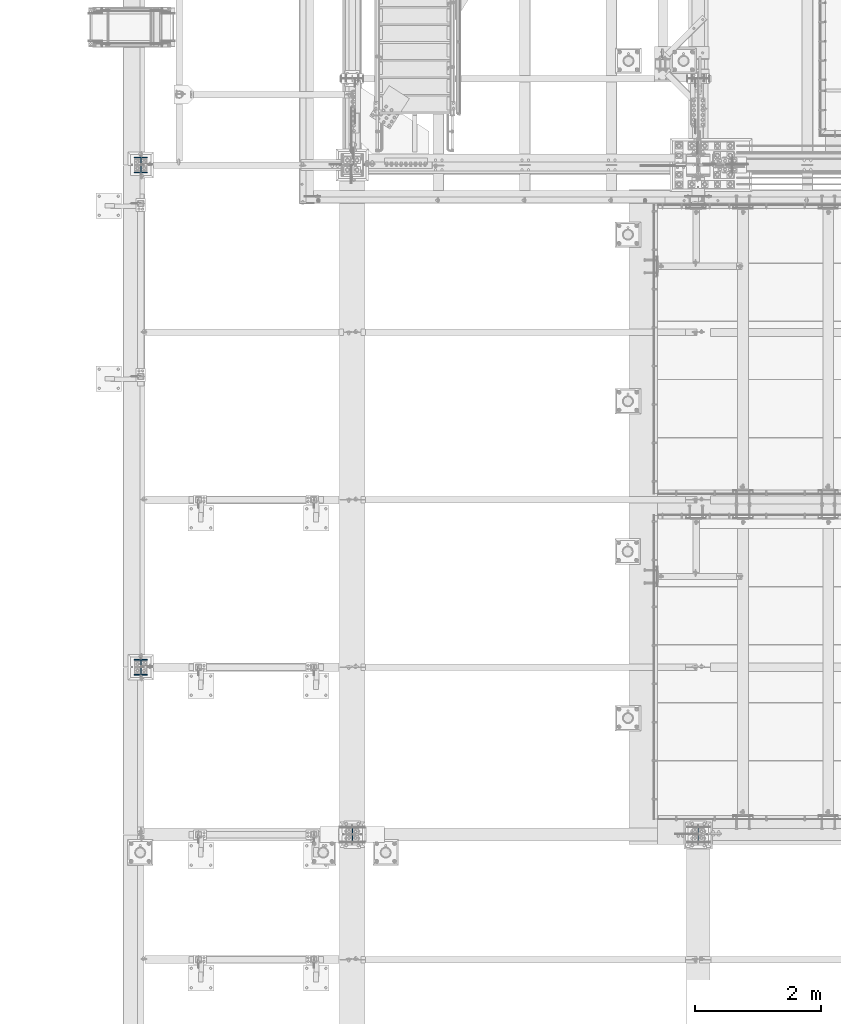
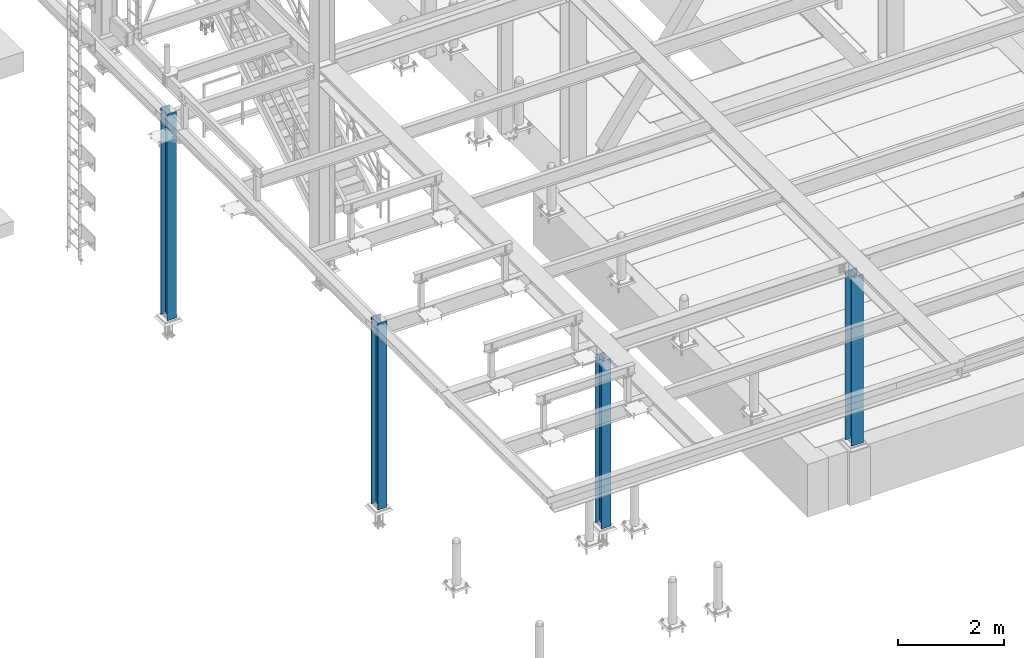
# One storey, part 1276 of 3843: 4 columns, 4 elements without a shape of their own.
"""IFC2X3 building model written with IfcOpenShell, lengths in millimetres."""

import ifcopenshell
import ifcopenshell.guid

model = None  # the IFC model being written
_history = None  # IfcOwnerHistory: only IFC2X3 demands one
_inside = {}  # id of a spatial element -> (the spatial element, [elements in it])
_under = {}  # id of a project, library or spatial element -> (it, [spatial elements below it])
_declared = {}  # id of a project -> (the project, [libraries it declares])
_typed = {}  # id of a type object -> (the type object, [elements of that type])
_made_of = {}  # id of a material, layer set ... -> (it, [elements and type objects made of it])


def new_model(schema):
    """Start an empty IFC model of exactly this schema.

    Asked for "IFC4X3", IfcOpenShell would pick the latest addendum, in which some entities
    have other attributes; the version numbers below select the first issue.
    IFC2X3 requires an IfcOwnerHistory on every rooted entity: one is made here for all.
    """
    global model, _history
    if schema == "IFC4X3":
        model = ifcopenshell.file(schema_version=(4, 3, 0, 0))
    else:
        model = ifcopenshell.file(schema=schema)
    _inside.clear()
    _under.clear()
    _declared.clear()
    _typed.clear()
    _made_of.clear()
    _history = None
    if model.schema == "IFC2X3":
        org = make("IfcOrganization", Name="unknown")
        user = make(
            "IfcPersonAndOrganization",
            ThePerson=make("IfcPerson", FamilyName="unknown"),
            TheOrganization=org,
        )
        app = make(
            "IfcApplication",
            ApplicationDeveloper=org,
            Version="unknown",
            ApplicationFullName="unknown",
            ApplicationIdentifier="unknown",
        )
        _history = make(
            "IfcOwnerHistory",
            OwningUser=user,
            OwningApplication=app,
            ChangeAction="ADDED",
            CreationDate=0,
        )
    return model


def make(cls, **values):
    """One entity of the class cls with the attributes given. An attribute that is None is left unset."""
    return model.create_entity(
        cls, **{name: value for name, value in values.items() if value is not None}
    )


def rooted(cls, **values):
    """An entity with a GlobalId (a new one), such as an element, a storey or a relation."""
    return make(cls, GlobalId=ifcopenshell.guid.new(), OwnerHistory=_history, **values)


def si_unit(unit_type, name, prefix=None):
    """IfcSIUnit, for example si_unit("LENGTHUNIT", "METRE", prefix="MILLI")."""
    return make("IfcSIUnit", UnitType=unit_type, Prefix=prefix, Name=name)


def assignment(units):
    """IfcUnitAssignment: the units of a project."""
    return None if units is None else make("IfcUnitAssignment", Units=units)


def point(xyz):
    """IfcCartesianPoint."""
    return None if xyz is None else make("IfcCartesianPoint", Coordinates=xyz)


def direction(xyz):
    """IfcDirection."""
    return None if xyz is None else make("IfcDirection", DirectionRatios=xyz)


def frame(location, z_axis=None, x_axis=None):
    """IfcAxis2Placement3D, a coordinate frame: its origin and axes. An axis left out is left unset."""
    return make(
        "IfcAxis2Placement3D",
        Location=point(location),
        Axis=direction(z_axis),
        RefDirection=direction(x_axis),
    )


def origin_with_axes():
    """The frame at (0, 0, 0) with the z axis (0, 0, 1) and the x axis (1, 0, 0) written out."""
    return frame((0.0, 0.0, 0.0), z_axis=(0.0, 0.0, 1.0), x_axis=(1.0, 0.0, 0.0))


def place(relative_to, where):
    """IfcLocalPlacement: puts the frame where relative to a parent placement (None: the world)."""
    return make(
        "IfcLocalPlacement", PlacementRelTo=relative_to, RelativePlacement=where
    )


def context(
    kind, dimensions, precision=None, world=None, true_north=None, identifier=None
):
    """IfcGeometricRepresentationContext, for example the 3D "Model" context."""
    return make(
        "IfcGeometricRepresentationContext",
        ContextIdentifier=identifier,
        ContextType=kind,
        CoordinateSpaceDimension=dimensions,
        Precision=precision,
        WorldCoordinateSystem=world,
        TrueNorth=true_north,
    )


def subcontext(parent, identifier, kind, view, scale=None):
    """IfcGeometricRepresentationSubContext, for example "Body" below "Model"."""
    return make(
        "IfcGeometricRepresentationSubContext",
        ContextIdentifier=identifier,
        ContextType=kind,
        ParentContext=parent,
        TargetScale=scale,
        TargetView=view,
    )


def project(units=None, contexts=None):
    """IfcProject with its units and contexts."""
    return rooted(
        "IfcProject",
        Name="project",
        RepresentationContexts=contexts,
        UnitsInContext=assignment(units),
    )


def spatial(cls, under=None, at=None, **own):
    """A site, building, storey or space (cls), placed at a placement, below another one or the project."""
    s = rooted(cls, ObjectPlacement=at, **own)
    if under is not None:
        _under.setdefault(under.id(), (under, []))[1].append(s)
    return s


def faces_of(points, faces, orient=None, outer=None):
    """IfcFace entities. A face is a list of loops; a loop is a list of indices into points, from 0.

    orient and outer hold one flag for each loop. By default every Orientation is true, the
    first loop of a face is its IfcFaceOuterBound and the others are IfcFaceBound.
    """
    made = []
    for i, loops in enumerate(faces):
        bounds = []
        for j, loop in enumerate(loops):
            is_outer = j == 0 if outer is None else outer[i][j]
            bounds.append(
                make(
                    "IfcFaceOuterBound" if is_outer else "IfcFaceBound",
                    Bound=make("IfcPolyLoop", Polygon=[points[k] for k in loop]),
                    Orientation=True if orient is None else orient[i][j],
                )
            )
        made.append(make("IfcFace", Bounds=bounds))
    return made


def faceted_brep(points, faces, orient=None, outer=None, voids=None):
    """IfcFacetedBrep: a solid bounded by flat faces; with voids (closed shells), ...WithVoids."""
    shared = [point(p) for p in points]
    hull = make("IfcClosedShell", CfsFaces=faces_of(shared, faces, orient, outer))
    if voids is None:
        return make("IfcFacetedBrep", Outer=hull)
    return make(
        "IfcFacetedBrepWithVoids",
        Outer=hull,
        Voids=[
            make(cls, CfsFaces=faces_of(shared, fs, o, b)) for cls, fs, o, b in voids
        ],
    )


def shape(context_of_items, identifier, shape_type, items):
    """IfcShapeRepresentation: the items that make up one representation, for example the "Body"."""
    return make(
        "IfcShapeRepresentation",
        ContextOfItems=context_of_items,
        RepresentationIdentifier=identifier,
        RepresentationType=shape_type,
        Items=items,
    )


def material(Name=None, Category=None):
    """IfcMaterial."""
    return make("IfcMaterial", Name=Name, Category=Category)


def made_of(thing, what):
    """Note that an element or type object is made of a material, layer set ...; save() writes the relation."""
    if what is not None:
        _made_of.setdefault(what.id(), (what, []))[1].append(thing)
    return thing


def type_object(cls, material=None, **own):
    """A type object (cls), such as IfcWallType, which elements share."""
    return made_of(rooted(cls, **own), material)


def element(
    cls,
    number,
    at=None,
    inside=None,
    cuts=None,
    type_object=None,
    material=None,
    context=None,
    identifier="Body",
    shape_type=None,
    held_by="IfcProductDefinitionShape",
    body=None,
    shapes=None,
    **own,
):
    """One element of the class cls, such as IfcWall. Its Tag is "e" and its number.

    at: its placement. inside: the storey or other place that contains it. cuts: it is an
    opening in that element (IfcRelVoidsElement). A single representation is given by context,
    identifier, shape_type and body (its items); several are given by shapes. held_by: the class
    of the entity that holds the representations. save() writes the other relations.
    """
    e = rooted(cls, Tag="e%d" % number, ObjectPlacement=at, **own)
    if body is not None:
        shapes = [shape(context, identifier, shape_type, body)]
    if shapes is not None:
        e.Representation = make(held_by, Representations=shapes)
    if inside is not None:
        _inside.setdefault(inside.id(), (inside, []))[1].append(e)
    if cuts is not None:
        rooted(
            "IfcRelVoidsElement", RelatingBuildingElement=cuts, RelatedOpeningElement=e
        )
    if type_object is not None:
        _typed.setdefault(type_object.id(), (type_object, []))[1].append(e)
    return made_of(e, material)


def aggregate(whole, parts):
    """IfcRelAggregates: a whole, such as a stair, and the parts it consists of."""
    return rooted("IfcRelAggregates", RelatingObject=whole, RelatedObjects=parts)


def save(model, path):
    """Write the relations noted so far, then the file.

    IfcRelAggregates (storeys below a building ...), IfcRelContainedInSpatialStructure (elements
    in a storey), IfcRelDefinesByType, IfcRelAssociatesMaterial and IfcRelDeclares: one each for
    every whole, place, type object, material and project.
    """
    for whole, parts in _under.values():
        aggregate(whole, parts)
    for where, things in _inside.values():
        rooted(
            "IfcRelContainedInSpatialStructure",
            RelatedElements=things,
            RelatingStructure=where,
        )
    for kind, things in _typed.values():
        rooted("IfcRelDefinesByType", RelatedObjects=things, RelatingType=kind)
    for what, things in _made_of.values():
        rooted("IfcRelAssociatesMaterial", RelatedObjects=things, RelatingMaterial=what)
    for by, libraries in _declared.values():
        rooted("IfcRelDeclares", RelatingContext=by, RelatedDefinitions=libraries)
    model.write(path)


model = new_model("IFC2X3")

# Units and contexts
model_context = context("Model", 3, precision=1e-05, world=origin_with_axes())
body_context = subcontext(model_context, "Body", "Model", "MODEL_VIEW")
ifc_project = project(units=[si_unit("LENGTHUNIT", "METRE", prefix="MILLI"), si_unit("AREAUNIT", "SQUARE_METRE"), si_unit("VOLUMEUNIT", "CUBIC_METRE"), si_unit("MASSUNIT", "GRAM", prefix="KILO"), si_unit("TIMEUNIT", "SECOND"), si_unit("PLANEANGLEUNIT", "RADIAN"), si_unit("SOLIDANGLEUNIT", "STERADIAN"), si_unit("THERMODYNAMICTEMPERATUREUNIT", "DEGREE_CELSIUS"), si_unit("LUMINOUSINTENSITYUNIT", "LUMEN")], contexts=[model_context])

# Site, building, storey
site_placement = place(None, origin_with_axes())
site = spatial("IfcSite", under=ifc_project, at=site_placement, CompositionType="ELEMENT")
building_placement = place(site_placement, origin_with_axes())
building = spatial("IfcBuilding", under=site, at=building_placement, Name="Undefined", CompositionType="ELEMENT")
storey_placement = place(building_placement, origin_with_axes())
storey = spatial("IfcBuildingStorey", under=building, at=storey_placement, Name="Undefined", CompositionType="ELEMENT", Elevation=0.0)

# Assembly, column
assembly_1_placement = place(storey_placement, origin_with_axes())
assembly_1 = element("IfcElementAssembly", 1, at=assembly_1_placement, inside=storey, Name="COLUMN", AssemblyPlace="NOTDEFINED", PredefinedType="RIGID_FRAME")
ifc_material = material(Name="STEEL/A992")
column_type_1 = type_object("IfcColumnType", Name="W10X60", PredefinedType="NOTDEFINED")
column_1_placement = place(assembly_1_placement, frame((42062.4, 14998.7, 30480.0), z_axis=(0.0, 1.0, 0.0), x_axis=(0.0, 0.0, 1.0)))
column_1 = element("IfcColumn", 2, at=column_1_placement, type_object=column_type_1, material=ifc_material, Name="COLUMN", ObjectType="W10X60", context=body_context, shape_type="Brep", body=[
    faceted_brep([(63.5, 128.587499999994, -130.174999999999), (63.5, 128.587499999994, -112.7125), (3952.87500000001, 128.587500000001, -112.7125), (3952.87500000001, 128.587500000001, -130.174999999999), (63.5, 5.55624999999418, -112.7125), (3952.87500000001, 5.55625000000146, -112.7125), (63.5, 5.55624999999418, 112.7125), (3952.87500000001, 5.55625000000146, 112.7125), (63.5, 128.587499999994, 112.7125), (3952.87500000001, 128.587500000001, 112.7125), (63.5, 128.587499999994, 130.174999999999), (3952.87500000001, 128.587500000001, 130.174999999999), (63.5, -128.587499999994, 130.174999999999), (3952.87500000001, -128.587500000001, 130.174999999999), (63.5, -128.587499999994, 112.7125), (3952.87500000001, -128.587500000001, 112.7125), (63.5, -5.55624999999418, 112.7125), (3952.87500000001, -5.55625000000146, 112.7125), (63.5, -5.55624999999418, -112.7125), (3952.87500000001, -5.55625000000146, -112.7125), (63.5, -128.587499999994, -112.7125), (3952.87500000001, -128.587500000001, -112.7125), (63.5, -128.587499999994, -130.174999999999), (3952.87500000001, -128.587500000001, -130.174999999999)], [[[0, 1, 2, 3]], [[1, 4, 5, 2]], [[4, 6, 7, 5]], [[6, 8, 9, 7]], [[8, 10, 11, 9]], [[10, 12, 13, 11]], [[12, 14, 15, 13]], [[14, 16, 17, 15]], [[16, 18, 19, 17]], [[18, 20, 21, 19]], [[20, 22, 23, 21]], [[22, 0, 3, 23]], [[5, 7, 9, 11, 13, 15, 17, 19, 21, 23, 3, 2]], [[22, 20, 18, 16, 14, 12, 10, 8, 6, 4, 1, 0]]]),
])
aggregate(assembly_1, [column_1])

assembly_2_placement = place(storey_placement, origin_with_axes())
assembly_2 = element("IfcElementAssembly", 3, at=assembly_2_placement, inside=storey, Name="COLUMN", AssemblyPlace="NOTDEFINED", PredefinedType="RIGID_FRAME")
column_type_2 = type_object("IfcColumnType", Name="W10X39", PredefinedType="NOTDEFINED")
column_2_placement = place(assembly_2_placement, frame((36576.0, 14998.7, 30480.0), z_axis=(0.0, 1.0, 0.0), x_axis=(0.0, 0.0, 1.0)))
column_2 = element("IfcColumn", 4, at=column_2_placement, type_object=column_type_2, material=ifc_material, Name="COLUMN", ObjectType="W10X39", context=body_context, shape_type="Brep", body=[
    faceted_brep([(63.4999999999964, 101.600000000006, -125.4125), (63.4999999999964, 101.600000000006, -112.7125), (3930.65, 101.599999999999, -112.7125), (3930.65, 101.599999999999, -125.4125), (63.4999999999964, 3.96875, -112.7125), (3930.65, 3.96875, -112.7125), (63.4999999999964, 3.96875, 112.7125), (3930.65, 3.96875, 112.7125), (63.4999999999964, 101.600000000006, 112.7125), (3930.65, 101.599999999999, 112.7125), (63.4999999999964, 101.600000000006, 125.4125), (3930.65, 101.599999999999, 125.4125), (63.4999999999964, -101.600000000006, 125.4125), (3930.65, -101.599999999999, 125.4125), (63.4999999999964, -101.600000000006, 112.7125), (3930.65, -101.599999999999, 112.7125), (63.4999999999964, -3.96875, 112.7125), (3930.65, -3.96875, 112.7125), (63.4999999999964, -3.96875, -112.7125), (3930.65, -3.96875, -112.7125), (63.4999999999964, -101.600000000006, -112.7125), (3930.65, -101.599999999999, -112.7125), (63.4999999999964, -101.600000000006, -125.4125), (3930.65, -101.599999999999, -125.4125)], [[[0, 1, 2, 3]], [[1, 4, 5, 2]], [[4, 6, 7, 5]], [[6, 8, 9, 7]], [[8, 10, 11, 9]], [[10, 12, 13, 11]], [[12, 14, 15, 13]], [[14, 16, 17, 15]], [[16, 18, 19, 17]], [[18, 20, 21, 19]], [[20, 22, 23, 21]], [[22, 0, 3, 23]], [[5, 7, 9, 11, 13, 15, 17, 19, 21, 23, 3, 2]], [[22, 20, 18, 16, 14, 12, 10, 8, 6, 4, 1, 0]]]),
])
aggregate(assembly_2, [column_2])

assembly_3_placement = place(storey_placement, origin_with_axes())
assembly_3 = element("IfcElementAssembly", 5, at=assembly_3_placement, inside=storey, Name="COLUMN", AssemblyPlace="NOTDEFINED", PredefinedType="RIGID_FRAME")
column_3_placement = place(assembly_3_placement, frame((33223.2, 17653.0, 30480.0), z_axis=(0.0, 1.0, 0.0), x_axis=(0.0, 0.0, 1.0)))
column_3 = element("IfcColumn", 6, at=column_3_placement, type_object=column_type_2, material=ifc_material, Name="COLUMN", ObjectType="W10X39", context=body_context, shape_type="Brep", body=[
    faceted_brep([(63.4999999999964, 101.600000000006, -125.4125), (63.4999999999964, 101.600000000006, -112.7125), (4368.8, 101.599999999999, -112.712500000001), (4368.8, 101.599999999999, -125.412499999999), (63.4999999999964, 3.96875, -112.7125), (4368.8, 3.96875, -112.712500000001), (63.4999999999964, 3.96875, 112.7125), (4368.8, 3.96875, 112.712500000001), (63.4999999999964, 101.600000000006, 112.7125), (4368.8, 101.599999999999, 112.712500000001), (63.4999999999964, 101.600000000006, 125.4125), (4368.8, 101.599999999999, 125.412499999999), (63.4999999999964, -101.600000000006, 125.4125), (4368.8, -101.599999999999, 125.412499999999), (63.4999999999964, -101.600000000006, 112.7125), (4368.8, -101.599999999999, 112.712500000001), (63.4999999999964, -3.96875, 112.7125), (4368.8, -3.96875, 112.712500000001), (63.4999999999964, -3.96875, -112.7125), (4368.8, -3.96875, -112.712500000001), (63.4999999999964, -101.600000000006, -112.7125), (4368.8, -101.599999999999, -112.712500000001), (63.4999999999964, -101.600000000006, -125.4125), (4368.8, -101.599999999999, -125.412499999999)], [[[0, 1, 2, 3]], [[1, 4, 5, 2]], [[4, 6, 7, 5]], [[6, 8, 9, 7]], [[8, 10, 11, 9]], [[10, 12, 13, 11]], [[12, 14, 15, 13]], [[14, 16, 17, 15]], [[16, 18, 19, 17]], [[18, 20, 21, 19]], [[20, 22, 23, 21]], [[22, 0, 3, 23]], [[5, 7, 9, 11, 13, 15, 17, 19, 21, 23, 3, 2]], [[22, 20, 18, 16, 14, 12, 10, 8, 6, 4, 1, 0]]]),
])
aggregate(assembly_3, [column_3])

assembly_4_placement = place(storey_placement, origin_with_axes())
assembly_4 = element("IfcElementAssembly", 7, at=assembly_4_placement, inside=storey, Name="COLUMN", AssemblyPlace="NOTDEFINED", PredefinedType="RIGID_FRAME")
column_4_placement = place(assembly_4_placement, frame((33223.2, 25615.9, 30022.8), z_axis=(0.0, 1.0, 0.0), x_axis=(0.0, 0.0, 1.0)))
column_4 = element("IfcColumn", 8, at=column_4_placement, type_object=column_type_2, material=ifc_material, Name="COLUMN", ObjectType="W10X39", context=body_context, shape_type="Brep", body=[
    faceted_brep([(63.4999999999964, 101.600000000006, -125.4125), (63.4999999999964, 101.600000000006, -112.7125), (4826.00000000001, 101.600000000006, -112.7125), (4826.00000000001, 101.600000000006, -125.4125), (63.4999999999964, 3.96875, -112.7125), (4826.00000000001, 3.96875, -112.7125), (63.4999999999964, 3.96875, 112.7125), (4826.00000000001, 3.96875, 112.7125), (63.4999999999964, 101.600000000006, 112.7125), (4826.00000000001, 101.600000000006, 112.7125), (63.4999999999964, 101.600000000006, 125.4125), (4826.00000000001, 101.600000000006, 125.4125), (63.4999999999964, -101.600000000006, 125.4125), (4826.00000000001, -101.600000000006, 125.4125), (63.4999999999964, -101.600000000006, 112.7125), (4826.00000000001, -101.600000000006, 112.7125), (63.4999999999964, -3.96875, 112.7125), (4826.00000000001, -3.96875, 112.7125), (63.4999999999964, -3.96875, -112.7125), (4826.00000000001, -3.96875, -112.7125), (63.4999999999964, -101.600000000006, -112.7125), (4826.00000000001, -101.600000000006, -112.7125), (63.4999999999964, -101.600000000006, -125.4125), (4826.00000000001, -101.600000000006, -125.4125)], [[[0, 1, 2, 3]], [[1, 4, 5, 2]], [[4, 6, 7, 5]], [[6, 8, 9, 7]], [[8, 10, 11, 9]], [[10, 12, 13, 11]], [[12, 14, 15, 13]], [[14, 16, 17, 15]], [[16, 18, 19, 17]], [[18, 20, 21, 19]], [[20, 22, 23, 21]], [[22, 0, 3, 23]], [[5, 7, 9, 11, 13, 15, 17, 19, 21, 23, 3, 2]], [[22, 20, 18, 16, 14, 12, 10, 8, 6, 4, 1, 0]]]),
])
aggregate(assembly_4, [column_4])

save(model, "model.ifc")
